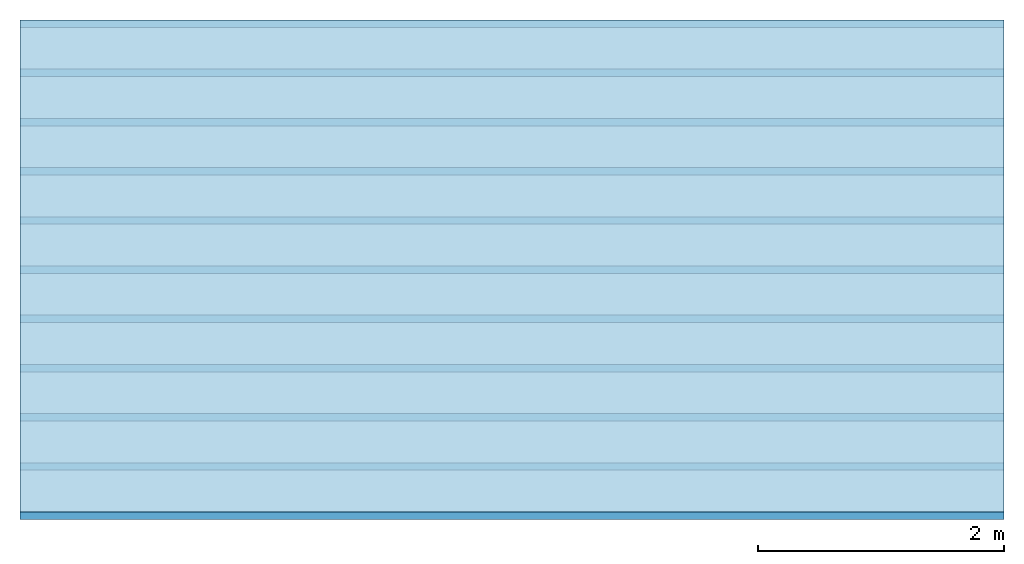
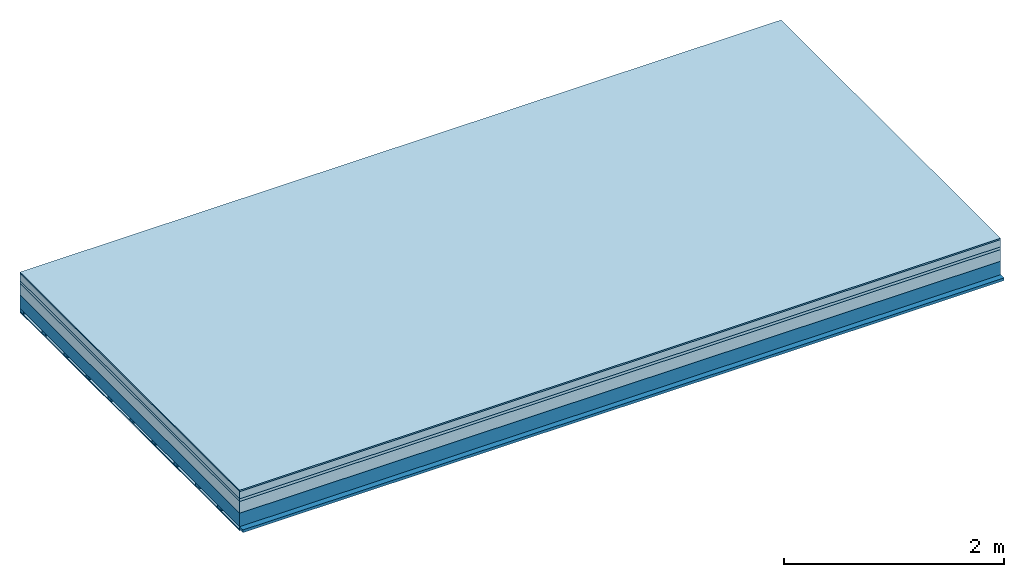
# One storey: 6 plates, 2 members, 1 element without a shape of its own.
"""IFC4 building model written with IfcOpenShell, lengths in metres."""

from ifc_helpers import new_model, si_unit, derived_unit, direction, frame, frame_2d, origin, origin_with_axes, place, context, project, spatial, rectangle, extrude, material, layer, layer_set, type_object, element, aggregate, save


model = new_model("IFC4")

# Units and contexts
plan_context = context("Plan", 3, precision=1e-05, world=origin(), true_north=direction((0.0, 1.0)))
model_context = context("Model", 3, precision=1e-05, world=origin(), true_north=direction((0.0, 1.0)))
ifc_project = project(units=[si_unit("LENGTHUNIT", "METRE"), derived_unit("SOUNDPRESSUREUNIT", [(si_unit("PRESSUREUNIT", "PASCAL", prefix="MICRO"), 0)]), si_unit("ENERGYUNIT", "JOULE", prefix="MEGA"), si_unit("MASSUNIT", "GRAM", prefix="KILO"), derived_unit("THERMALTRANSMITTANCEUNIT", [(si_unit("POWERUNIT", "WATT"), 1), (si_unit("AREAUNIT", "SQUARE_METRE"), -1), (si_unit("THERMODYNAMICTEMPERATUREUNIT", "KELVIN"), -1)]), derived_unit("AREADENSITYUNIT", [(si_unit("MASSUNIT", "GRAM", prefix="KILO"), 1), (si_unit("AREAUNIT", "SQUARE_METRE"), -1)]), derived_unit("USERDEFINED", [(si_unit("ENERGYUNIT", "JOULE", prefix="MEGA"), 1), (si_unit("AREAUNIT", "SQUARE_METRE"), -1)])], contexts=[plan_context, model_context])

# Site, building, storey
site = spatial("IfcSite", under=ifc_project)
building_placement = place(None, origin())
building = spatial("IfcBuilding", under=site, at=building_placement)
storey_placement = place(building_placement, origin())
storey = spatial("IfcBuildingStorey", under=building, at=storey_placement)

# Slab, members, plates
ifc_material_1 = material(Category="11.013")
ifc_layer_1 = layer(ifc_material_1, 0.015, Name="Flooring")
ifc_material_2 = material(Name="Cement screed", Category="04.006")
ifc_layer_2 = layer(ifc_material_2, 0.08, Name="On-material")
ifc_material_3 = material(Name="Wood fiber generic product", Category="10.009")
ifc_layer_3 = layer(ifc_material_3, 0.03, Name="Impact sound insulation")
ifc_material_4 = material(Category="01.002")
ifc_layer_4 = layer(ifc_material_4, 0.13, Name="Sub-floor")
ifc_material_5 = material(Name="Rigid, of the art")
ifc_layer_5 = layer(ifc_material_5, 0.0, Name="Bond")
ifc_layer_6 = layer(None, 0.15, Name="Supporting structure")
ifc_material_6 = material(Name="of the art")
ifc_layer_7 = layer(ifc_material_6, 0.0, Name="Bond")
ifc_layer_8 = layer(None, 0.03, Name="Battens / profiles")
ifc_material_7 = material(Name="Plasterboard type A", Category="03.008")
ifc_layer_9 = layer(ifc_material_7, 0.0125, Name="Ceiling covering 1st layer")
ifc_material_8 = material(Category="04.001")
ifc_layer_10 = layer(ifc_material_8, 0.003, Name="Surface / treatment")
ifc_layer_set = layer_set([ifc_layer_1, ifc_layer_2, ifc_layer_3, ifc_layer_4, ifc_layer_5, ifc_layer_6, ifc_layer_7, ifc_layer_8, ifc_layer_9, ifc_layer_10])
slab_type = type_object("IfcSlabType", Name="A2227", PredefinedType="NOTDEFINED", material=ifc_layer_set)
slab_placement = place(None, frame((0.0, 0.0, 0.0), z_axis=(0.0, 0.0, -1.0), x_axis=(1.0, 0.0, 0.0)))
slab = element("IfcSlab", 1, at=slab_placement, inside=storey, type_object=slab_type, material=ifc_layer_set, Name="Slab #1")
ifc_material_9 = material(Name="Solid timber panel")
member_1_placement = place(slab_placement, origin())
member_1 = element("IfcMember", 2, at=member_1_placement, material=ifc_material_9, Name="Supporting structure", context=plan_context, shape_type="SweptSolid", body=[
    extrude(rectangle(XDim=1.0, YDim=0.15, at=frame_2d((0.5, 0.075), x_axis=(1.0, 0.0))), frame((0.0, 4.0, 0.255), z_axis=(0.0, -1.0, 0.0), x_axis=(1.0, 0.0, 0.0)), (0.0, 0.0, 1.0), 4.0),
    extrude(rectangle(XDim=1.0, YDim=0.15, at=frame_2d((0.5, 0.075), x_axis=(1.0, 0.0))), frame((1.0, 4.0, 0.255), z_axis=(0.0, -1.0, 0.0), x_axis=(1.0, 0.0, 0.0)), (0.0, 0.0, 1.0), 4.0),
    extrude(rectangle(XDim=1.0, YDim=0.15, at=frame_2d((0.5, 0.075), x_axis=(1.0, 0.0))), frame((2.0, 4.0, 0.255), z_axis=(0.0, -1.0, 0.0), x_axis=(1.0, 0.0, 0.0)), (0.0, 0.0, 1.0), 4.0),
    extrude(rectangle(XDim=1.0, YDim=0.15, at=frame_2d((0.5, 0.075), x_axis=(1.0, 0.0))), frame((3.0, 4.0, 0.255), z_axis=(0.0, -1.0, 0.0), x_axis=(1.0, 0.0, 0.0)), (0.0, 0.0, 1.0), 4.0),
    extrude(rectangle(XDim=1.0, YDim=0.15, at=frame_2d((0.5, 0.075), x_axis=(1.0, 0.0))), frame((4.0, 4.0, 0.255), z_axis=(0.0, -1.0, 0.0), x_axis=(1.0, 0.0, 0.0)), (0.0, 0.0, 1.0), 4.0),
    extrude(rectangle(XDim=1.0, YDim=0.15, at=frame_2d((0.5, 0.075), x_axis=(1.0, 0.0))), frame((5.0, 4.0, 0.255), z_axis=(0.0, -1.0, 0.0), x_axis=(1.0, 0.0, 0.0)), (0.0, 0.0, 1.0), 4.0),
    extrude(rectangle(XDim=1.0, YDim=0.15, at=frame_2d((0.5, 0.075), x_axis=(1.0, 0.0))), frame((6.0, 4.0, 0.255), z_axis=(0.0, -1.0, 0.0), x_axis=(1.0, 0.0, 0.0)), (0.0, 0.0, 1.0), 4.0),
    extrude(rectangle(XDim=1.0, YDim=0.15, at=frame_2d((0.5, 0.075), x_axis=(1.0, 0.0))), frame((7.0, 4.0, 0.255), z_axis=(0.0, -1.0, 0.0), x_axis=(1.0, 0.0, 0.0)), (0.0, 0.0, 1.0), 4.0),
])
ifc_material_10 = material()
member_2_placement = place(slab_placement, origin())
member_2 = element("IfcMember", 3, at=member_2_placement, material=ifc_material_10, Name="Battens / profiles", context=plan_context, shape_type="SweptSolid", body=[
    extrude(rectangle(XDim=0.06, YDim=0.03, at=frame_2d((0.03, 0.015), x_axis=(1.0, 0.0))), frame((0.0, 0.0, 0.405), z_axis=(1.0, 0.0, 0.0), x_axis=(0.0, 1.0, 0.0)), (0.0, 0.0, 1.0), 8.0),
    extrude(rectangle(XDim=0.06, YDim=0.03, at=frame_2d((0.03, 0.015), x_axis=(1.0, 0.0))), frame((0.0, 0.4, 0.405), z_axis=(1.0, 0.0, 0.0), x_axis=(0.0, 1.0, 0.0)), (0.0, 0.0, 1.0), 8.0),
    extrude(rectangle(XDim=0.06, YDim=0.03, at=frame_2d((0.03, 0.015), x_axis=(1.0, 0.0))), frame((0.0, 0.8, 0.405), z_axis=(1.0, 0.0, 0.0), x_axis=(0.0, 1.0, 0.0)), (0.0, 0.0, 1.0), 8.0),
    extrude(rectangle(XDim=0.06, YDim=0.03, at=frame_2d((0.03, 0.015), x_axis=(1.0, 0.0))), frame((0.0, 1.2, 0.405), z_axis=(1.0, 0.0, 0.0), x_axis=(0.0, 1.0, 0.0)), (0.0, 0.0, 1.0), 8.0),
    extrude(rectangle(XDim=0.06, YDim=0.03, at=frame_2d((0.03, 0.015), x_axis=(1.0, 0.0))), frame((0.0, 1.6, 0.405), z_axis=(1.0, 0.0, 0.0), x_axis=(0.0, 1.0, 0.0)), (0.0, 0.0, 1.0), 8.0),
    extrude(rectangle(XDim=0.06, YDim=0.03, at=frame_2d((0.03, 0.015), x_axis=(1.0, 0.0))), frame((0.0, 2.0, 0.405), z_axis=(1.0, 0.0, 0.0), x_axis=(0.0, 1.0, 0.0)), (0.0, 0.0, 1.0), 8.0),
    extrude(rectangle(XDim=0.06, YDim=0.03, at=frame_2d((0.03, 0.015), x_axis=(1.0, 0.0))), frame((0.0, 2.4, 0.405), z_axis=(1.0, 0.0, 0.0), x_axis=(0.0, 1.0, 0.0)), (0.0, 0.0, 1.0), 8.0),
    extrude(rectangle(XDim=0.06, YDim=0.03, at=frame_2d((0.03, 0.015), x_axis=(1.0, 0.0))), frame((0.0, 2.8, 0.405), z_axis=(1.0, 0.0, 0.0), x_axis=(0.0, 1.0, 0.0)), (0.0, 0.0, 1.0), 8.0),
    extrude(rectangle(XDim=0.06, YDim=0.03, at=frame_2d((0.03, 0.015), x_axis=(1.0, 0.0))), frame((0.0, 3.2, 0.405), z_axis=(1.0, 0.0, 0.0), x_axis=(0.0, 1.0, 0.0)), (0.0, 0.0, 1.0), 8.0),
    extrude(rectangle(XDim=0.06, YDim=0.03, at=frame_2d((0.03, 0.015), x_axis=(1.0, 0.0))), frame((0.0, 3.6, 0.405), z_axis=(1.0, 0.0, 0.0), x_axis=(0.0, 1.0, 0.0)), (0.0, 0.0, 1.0), 8.0),
    extrude(rectangle(XDim=0.06, YDim=0.03, at=frame_2d((0.03, 0.015), x_axis=(1.0, 0.0))), frame((0.0, 4.0, 0.405), z_axis=(1.0, 0.0, 0.0), x_axis=(0.0, 1.0, 0.0)), (0.0, 0.0, 1.0), 8.0),
])
plate_1_placement = place(slab_placement, origin())
plate_1 = element("IfcPlate", 4, at=plate_1_placement, material=ifc_material_1, Name="Flooring", context=plan_context, shape_type="SweptSolid", body=[
    extrude(rectangle(XDim=8.0, YDim=4.0, at=frame_2d((4.0, 2.0), x_axis=(1.0, 0.0))), origin_with_axes(), (0.0, 0.0, 1.0), 0.015),
])
plate_2_placement = place(slab_placement, origin())
plate_2 = element("IfcPlate", 5, at=plate_2_placement, material=ifc_material_2, Name="On-material", context=plan_context, shape_type="SweptSolid", body=[
    extrude(rectangle(XDim=8.0, YDim=4.0, at=frame_2d((4.0, 2.0), x_axis=(1.0, 0.0))), frame((0.0, 0.0, 0.015), z_axis=(0.0, 0.0, 1.0), x_axis=(1.0, 0.0, 0.0)), (0.0, 0.0, 1.0), 0.08),
])
plate_3_placement = place(slab_placement, origin())
plate_3 = element("IfcPlate", 6, at=plate_3_placement, material=ifc_material_3, Name="Impact sound insulation", context=plan_context, shape_type="SweptSolid", body=[
    extrude(rectangle(XDim=8.0, YDim=4.0, at=frame_2d((4.0, 2.0), x_axis=(1.0, 0.0))), frame((0.0, 0.0, 0.095), z_axis=(0.0, 0.0, 1.0), x_axis=(1.0, 0.0, 0.0)), (0.0, 0.0, 1.0), 0.03),
])
plate_4_placement = place(slab_placement, origin())
plate_4 = element("IfcPlate", 7, at=plate_4_placement, material=ifc_material_4, Name="Sub-floor", context=plan_context, shape_type="SweptSolid", body=[
    extrude(rectangle(XDim=8.0, YDim=4.0, at=frame_2d((4.0, 2.0), x_axis=(1.0, 0.0))), frame((0.0, 0.0, 0.125), z_axis=(0.0, 0.0, 1.0), x_axis=(1.0, 0.0, 0.0)), (0.0, 0.0, 1.0), 0.13),
])
plate_5_placement = place(slab_placement, origin())
plate_5 = element("IfcPlate", 8, at=plate_5_placement, material=ifc_material_7, Name="Ceiling covering 1st layer", context=plan_context, shape_type="SweptSolid", body=[
    extrude(rectangle(XDim=8.0, YDim=4.0, at=frame_2d((4.0, 2.0), x_axis=(1.0, 0.0))), frame((0.0, 0.0, 0.435), z_axis=(0.0, 0.0, 1.0), x_axis=(1.0, 0.0, 0.0)), (0.0, 0.0, 1.0), 0.0125),
])
plate_6_placement = place(slab_placement, origin())
plate_6 = element("IfcPlate", 9, at=plate_6_placement, material=ifc_material_8, Name="Surface / treatment", context=plan_context, shape_type="SweptSolid", body=[
    extrude(rectangle(XDim=8.0, YDim=4.0, at=frame_2d((4.0, 2.0), x_axis=(1.0, 0.0))), frame((0.0, 0.0, 0.4475), z_axis=(0.0, 0.0, 1.0), x_axis=(1.0, 0.0, 0.0)), (0.0, 0.0, 1.0), 0.003),
])
aggregate(slab, [plate_1, plate_2, plate_3, plate_4, member_1, member_2, plate_5, plate_6])

save(model, "model.ifc")
